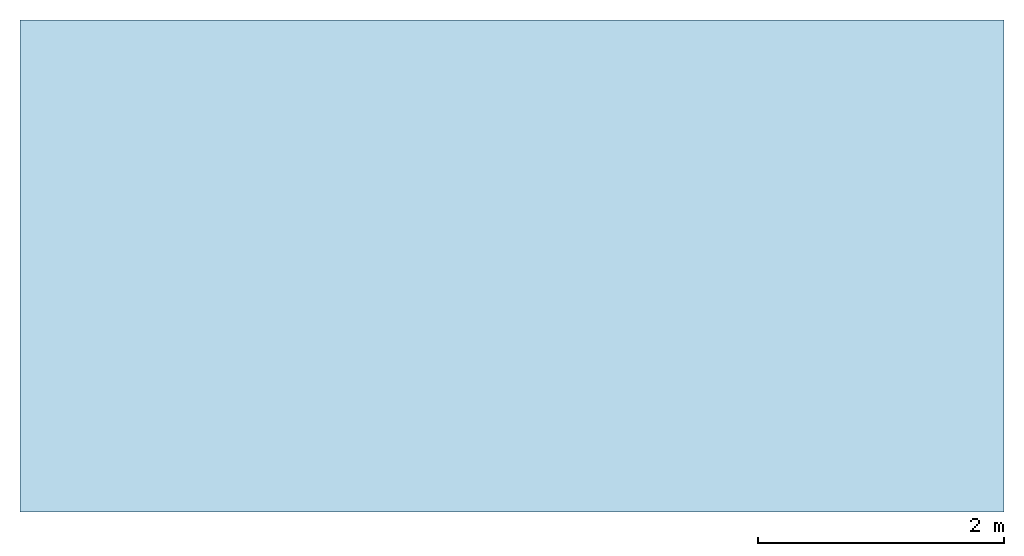
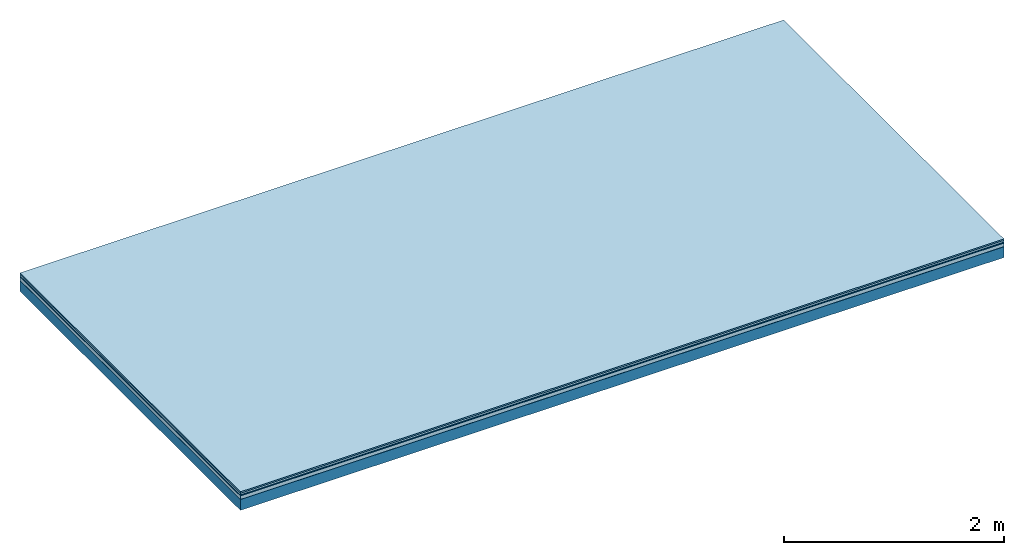
# One storey: 5 plates, 1 member, 1 element without a shape of its own.
"""IFC4 building model written with IfcOpenShell, lengths in metres."""

from ifc_helpers import new_model, si_unit, derived_unit, direction, frame, frame_2d, origin, origin_with_axes, place, context, project, spatial, rectangle, extrude, material, layer, layer_set, type_object, element, aggregate, save


model = new_model("IFC4")

# Units and contexts
plan_context = context("Plan", 3, precision=1e-05, world=origin(), true_north=direction((0.0, 1.0)))
model_context = context("Model", 3, precision=1e-05, world=origin(), true_north=direction((0.0, 1.0)))
ifc_project = project(units=[si_unit("LENGTHUNIT", "METRE"), derived_unit("SOUNDPRESSUREUNIT", [(si_unit("PRESSUREUNIT", "PASCAL", prefix="MICRO"), 0)]), si_unit("ENERGYUNIT", "JOULE", prefix="MEGA"), si_unit("MASSUNIT", "GRAM", prefix="KILO"), derived_unit("THERMALTRANSMITTANCEUNIT", [(si_unit("POWERUNIT", "WATT"), 1), (si_unit("AREAUNIT", "SQUARE_METRE"), -1), (si_unit("THERMODYNAMICTEMPERATUREUNIT", "KELVIN"), -1)]), derived_unit("AREADENSITYUNIT", [(si_unit("MASSUNIT", "GRAM", prefix="KILO"), 1), (si_unit("AREAUNIT", "SQUARE_METRE"), -1)]), derived_unit("USERDEFINED", [(si_unit("ENERGYUNIT", "JOULE", prefix="MEGA"), 1), (si_unit("AREAUNIT", "SQUARE_METRE"), -1)])], contexts=[plan_context, model_context])

# Site, building, storey
site = spatial("IfcSite", under=ifc_project)
building_placement = place(None, origin())
building = spatial("IfcBuilding", under=site, at=building_placement)
storey_placement = place(building_placement, origin())
storey = spatial("IfcBuildingStorey", under=building, at=storey_placement)

# Slab, member, plates
ifc_material_1 = material(Category="11.013")
ifc_layer_1 = layer(ifc_material_1, 0.015, Name="Flooring")
ifc_material_2 = material(Category="03.007")
ifc_layer_2 = layer(ifc_material_2, 0.02, Name="On-material")
ifc_material_3 = material(Name="Wood fiber generic product", Category="10.009")
ifc_layer_3 = layer(ifc_material_3, 0.01, Name="Impact sound insulation")
ifc_material_4 = material(Name="Cement panels, glued on sub-floor", Category="02.007")
ifc_layer_4 = layer(ifc_material_4, 0.04, Name="on Supporting structure")
ifc_material_5 = material(Name="protection", Category="09.007")
ifc_layer_5 = layer(ifc_material_5, 0.0005, Name="Sub-floor")
ifc_material_6 = material(Name="no composite action")
ifc_layer_6 = layer(ifc_material_6, 0.0, Name="Bond")
ifc_layer_7 = layer(None, 0.12, Name="Supporting structure")
ifc_layer_set = layer_set([ifc_layer_1, ifc_layer_2, ifc_layer_3, ifc_layer_4, ifc_layer_5, ifc_layer_6, ifc_layer_7])
slab_type = type_object("IfcSlabType", Name="A2060", PredefinedType="NOTDEFINED", material=ifc_layer_set)
slab_placement = place(None, frame((0.0, 0.0, 0.0), z_axis=(0.0, 0.0, -1.0), x_axis=(1.0, 0.0, 0.0)))
slab = element("IfcSlab", 1, at=slab_placement, inside=storey, type_object=slab_type, material=ifc_layer_set, Name="Slab #1")
ifc_material_7 = material(Name="Solid timber panel")
member_placement = place(slab_placement, origin())
member = element("IfcMember", 2, at=member_placement, material=ifc_material_7, Name="Supporting structure", context=plan_context, shape_type="SweptSolid", body=[
    extrude(rectangle(XDim=1.0, YDim=0.12, at=frame_2d((0.5, 0.06), x_axis=(1.0, 0.0))), frame((0.0, 4.0, 0.0855), z_axis=(0.0, -1.0, 0.0), x_axis=(1.0, 0.0, 0.0)), (0.0, 0.0, 1.0), 4.0),
    extrude(rectangle(XDim=1.0, YDim=0.12, at=frame_2d((0.5, 0.06), x_axis=(1.0, 0.0))), frame((1.0, 4.0, 0.0855), z_axis=(0.0, -1.0, 0.0), x_axis=(1.0, 0.0, 0.0)), (0.0, 0.0, 1.0), 4.0),
    extrude(rectangle(XDim=1.0, YDim=0.12, at=frame_2d((0.5, 0.06), x_axis=(1.0, 0.0))), frame((2.0, 4.0, 0.0855), z_axis=(0.0, -1.0, 0.0), x_axis=(1.0, 0.0, 0.0)), (0.0, 0.0, 1.0), 4.0),
    extrude(rectangle(XDim=1.0, YDim=0.12, at=frame_2d((0.5, 0.06), x_axis=(1.0, 0.0))), frame((3.0, 4.0, 0.0855), z_axis=(0.0, -1.0, 0.0), x_axis=(1.0, 0.0, 0.0)), (0.0, 0.0, 1.0), 4.0),
    extrude(rectangle(XDim=1.0, YDim=0.12, at=frame_2d((0.5, 0.06), x_axis=(1.0, 0.0))), frame((4.0, 4.0, 0.0855), z_axis=(0.0, -1.0, 0.0), x_axis=(1.0, 0.0, 0.0)), (0.0, 0.0, 1.0), 4.0),
    extrude(rectangle(XDim=1.0, YDim=0.12, at=frame_2d((0.5, 0.06), x_axis=(1.0, 0.0))), frame((5.0, 4.0, 0.0855), z_axis=(0.0, -1.0, 0.0), x_axis=(1.0, 0.0, 0.0)), (0.0, 0.0, 1.0), 4.0),
    extrude(rectangle(XDim=1.0, YDim=0.12, at=frame_2d((0.5, 0.06), x_axis=(1.0, 0.0))), frame((6.0, 4.0, 0.0855), z_axis=(0.0, -1.0, 0.0), x_axis=(1.0, 0.0, 0.0)), (0.0, 0.0, 1.0), 4.0),
    extrude(rectangle(XDim=1.0, YDim=0.12, at=frame_2d((0.5, 0.06), x_axis=(1.0, 0.0))), frame((7.0, 4.0, 0.0855), z_axis=(0.0, -1.0, 0.0), x_axis=(1.0, 0.0, 0.0)), (0.0, 0.0, 1.0), 4.0),
])
plate_1_placement = place(slab_placement, origin())
plate_1 = element("IfcPlate", 3, at=plate_1_placement, material=ifc_material_1, Name="Flooring", context=plan_context, shape_type="SweptSolid", body=[
    extrude(rectangle(XDim=8.0, YDim=4.0, at=frame_2d((4.0, 2.0), x_axis=(1.0, 0.0))), origin_with_axes(), (0.0, 0.0, 1.0), 0.015),
])
plate_2_placement = place(slab_placement, origin())
plate_2 = element("IfcPlate", 4, at=plate_2_placement, material=ifc_material_2, Name="On-material", context=plan_context, shape_type="SweptSolid", body=[
    extrude(rectangle(XDim=8.0, YDim=4.0, at=frame_2d((4.0, 2.0), x_axis=(1.0, 0.0))), frame((0.0, 0.0, 0.015), z_axis=(0.0, 0.0, 1.0), x_axis=(1.0, 0.0, 0.0)), (0.0, 0.0, 1.0), 0.02),
])
plate_3_placement = place(slab_placement, origin())
plate_3 = element("IfcPlate", 5, at=plate_3_placement, material=ifc_material_3, Name="Impact sound insulation", context=plan_context, shape_type="SweptSolid", body=[
    extrude(rectangle(XDim=8.0, YDim=4.0, at=frame_2d((4.0, 2.0), x_axis=(1.0, 0.0))), frame((0.0, 0.0, 0.035), z_axis=(0.0, 0.0, 1.0), x_axis=(1.0, 0.0, 0.0)), (0.0, 0.0, 1.0), 0.01),
])
plate_4_placement = place(slab_placement, origin())
plate_4 = element("IfcPlate", 6, at=plate_4_placement, material=ifc_material_4, Name="on Supporting structure", context=plan_context, shape_type="SweptSolid", body=[
    extrude(rectangle(XDim=8.0, YDim=4.0, at=frame_2d((4.0, 2.0), x_axis=(1.0, 0.0))), frame((0.0, 0.0, 0.045), z_axis=(0.0, 0.0, 1.0), x_axis=(1.0, 0.0, 0.0)), (0.0, 0.0, 1.0), 0.04),
])
plate_5_placement = place(slab_placement, origin())
plate_5 = element("IfcPlate", 7, at=plate_5_placement, material=ifc_material_5, Name="Sub-floor", context=plan_context, shape_type="SweptSolid", body=[
    extrude(rectangle(XDim=8.0, YDim=4.0, at=frame_2d((4.0, 2.0), x_axis=(1.0, 0.0))), frame((0.0, 0.0, 0.085), z_axis=(0.0, 0.0, 1.0), x_axis=(1.0, 0.0, 0.0)), (0.0, 0.0, 1.0), 0.0005),
])
aggregate(slab, [plate_1, plate_2, plate_3, plate_4, plate_5, member])

save(model, "model.ifc")
